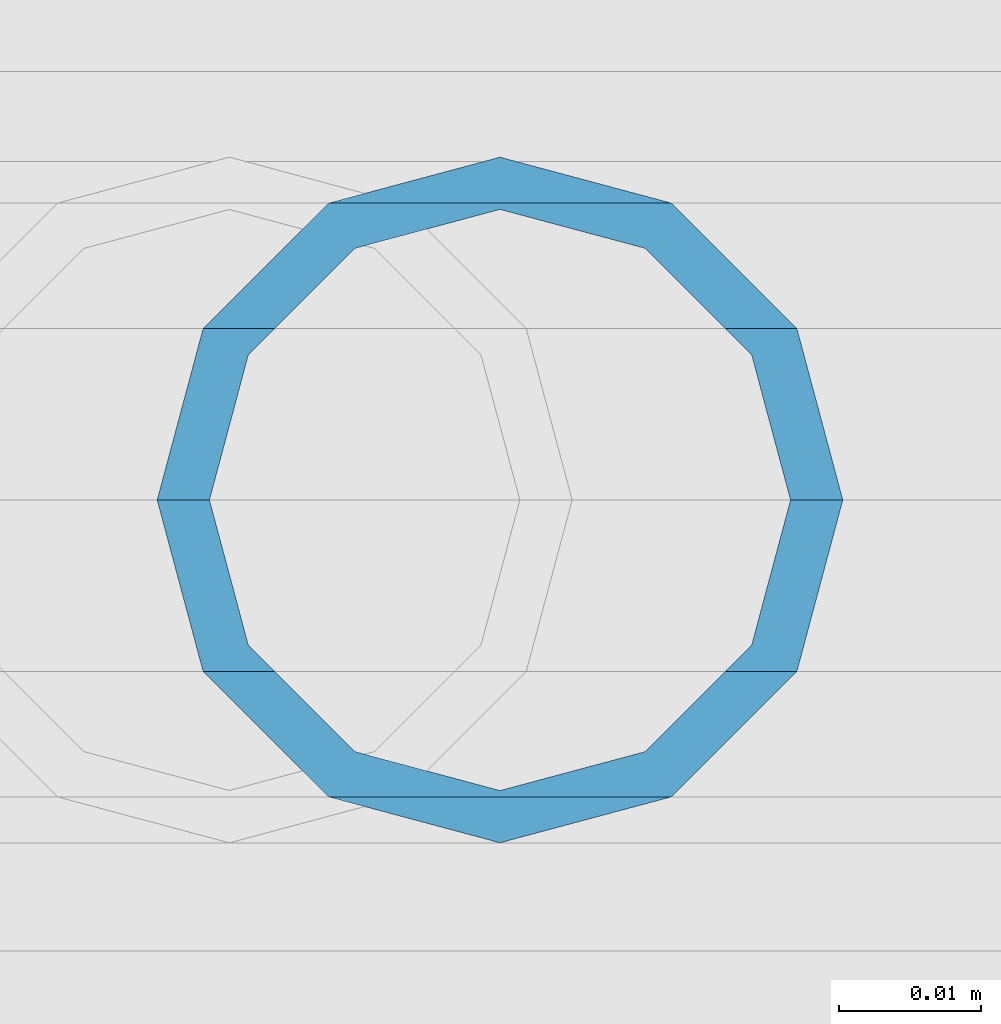
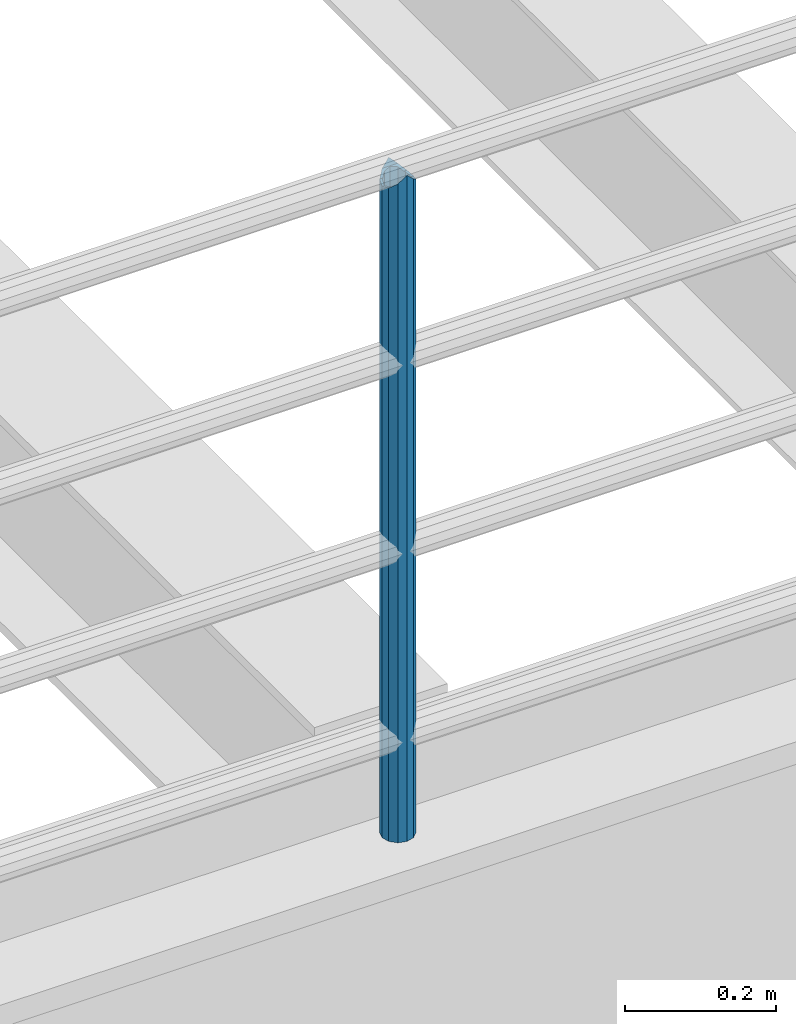
# One storey, part 636 of 1876: 1 column, 1 element without a shape of its own.
"""IFC2X3 building model written with IfcOpenShell, lengths in millimetres."""

from ifc_helpers import new_model, si_unit, frame, origin_with_axes, place, context, subcontext, project, spatial, faceted_brep, material, type_object, element, aggregate, save


model = new_model("IFC2X3")

# Units and contexts
model_context = context("Model", 3, precision=1e-05, world=origin_with_axes())
body_context = subcontext(model_context, "Body", "Model", "MODEL_VIEW")
ifc_project = project(units=[si_unit("LENGTHUNIT", "METRE", prefix="MILLI"), si_unit("AREAUNIT", "SQUARE_METRE"), si_unit("VOLUMEUNIT", "CUBIC_METRE"), si_unit("MASSUNIT", "GRAM", prefix="KILO"), si_unit("TIMEUNIT", "SECOND"), si_unit("PLANEANGLEUNIT", "RADIAN"), si_unit("SOLIDANGLEUNIT", "STERADIAN"), si_unit("THERMODYNAMICTEMPERATUREUNIT", "DEGREE_CELSIUS"), si_unit("LUMINOUSINTENSITYUNIT", "LUMEN")], contexts=[model_context])

# Site, building, storey
site_placement = place(None, origin_with_axes())
site = spatial("IfcSite", under=ifc_project, at=site_placement, CompositionType="ELEMENT")
building_placement = place(site_placement, origin_with_axes())
building = spatial("IfcBuilding", under=site, at=building_placement, Name="Undefined", CompositionType="ELEMENT")
storey_placement = place(building_placement, origin_with_axes())
storey = spatial("IfcBuildingStorey", under=building, at=storey_placement, Name="Undefined", CompositionType="ELEMENT", Elevation=0.0)

# Assembly, column
assembly_placement = place(storey_placement, origin_with_axes())
assembly = element("IfcElementAssembly", 1, at=assembly_placement, inside=storey, Name="RAIL", AssemblyPlace="NOTDEFINED", PredefinedType="RIGID_FRAME")
ifc_material = material()
column_type = type_object("IfcColumnType", Name="PIPE1-1/2SCH40", PredefinedType="NOTDEFINED")
column_placement = place(assembly_placement, frame((5067.30000007785, -4654.55000114554, 5130.8), z_axis=(1.0, 0.0, 0.0), x_axis=(0.0, 0.0, 1.0)))
column = element("IfcColumn", 2, at=column_placement, type_object=column_type, material=ifc_material, Name="POST", ObjectType="PIPE1-1/2SCH40", context=body_context, shape_type="Brep", body=[
    faceted_brep([(1055.42780700668, -12.0650000000001, 20.8971929933186), (1055.42780700668, -12.0650000000001, 15.8661214311805), (1054.93437856882, -10.2235000000001, 17.7076214311801), (1052.195, 0.0, 20.4470000000001), (1052.195, 0.0, 24.1300000000001), (1054.93437856882, 10.2235000000001, 17.7076214311801), (1055.42780700668, 12.0650000000001, 15.8661214311805), (1055.42780700668, 12.0650000000001, 20.8971929933186), (1076.325, 24.1300000000001, 0.0), (1064.26, 20.8971929933184, 12.0649999999996), (1064.25999999999, 20.8971929933186, -12.0649999999996), (1061.07042843786, 17.7076214311803, 10.2235000000001), (1063.80980700668, 20.4469999999999, 0.0), (1061.07042843786, 17.7076214311803, -10.2235000000001), (1055.42780700668, 12.0650000000001, -15.8661214311805), (1055.42780700667, 12.0649999999996, -20.8971929933186), (1054.93437856882, 10.2235000000001, -17.7076214311801), (1052.195, 0.0, -20.4470000000001), (1052.19499999999, 0.0, -24.1300000000001), (1055.42780700668, -12.0650000000001, -15.8661214311805), (1055.42780700667, -12.0649999999996, -20.8971929933186), (1054.93437856882, -10.2235000000001, -17.7076214311801), (1076.325, -24.1300000000001, 0.0), (1064.25999999999, -20.8971929933186, -12.0649999999996), (1064.26, -20.8971929933184, 12.0649999999996), (1061.07042843786, -17.7076214311803, -10.2235000000001), (1063.80980700668, -20.4469999999999, 0.0), (1061.07042843786, -17.7076214311803, 10.2235000000001), (0.0, -20.8971929933184, -12.0649999999996), (0.0, -12.0650000000001, -20.8971929933186), (-1.45519152283669e-11, 0.0, -24.130000000001), (0.0, 12.0650000000001, -20.8971929933186), (0.0, 20.8971929933184, -12.0649999999996), (0.0, 24.1299999999992, 0.0), (0.0, 20.8971929933184, 12.0649999999996), (0.0, 12.0650000000001, 20.8971929933186), (-1.45519152283669e-11, 0.0, 24.130000000001), (0.0, -12.0650000000001, 20.8971929933186), (0.0, -20.8971929933184, 12.0649999999996), (0.0, -24.1299999999992, 0.0), (0.0, -17.7076214311803, -10.2235000000001), (0.0, -10.2235000000001, -17.7076214311801), (-1.45519152283669e-11, 0.0, -20.4470000000001), (0.0, 10.2235000000001, -17.7076214311801), (0.0, 17.7076214311803, -10.2235000000001), (0.0, 20.4469999999999, 0.0), (0.0, 17.7076214311803, 10.2235000000001), (0.0, 10.2235000000001, 17.7076214311801), (-1.45519152283669e-11, 0.0, 20.4470000000001), (0.0, -10.2235000000001, 17.7076214311801), (0.0, -17.7076214311803, 10.2235000000001), (0.0, -20.4469999999999, 0.0)], [[[0, 1, 2, 3, 4]], [[4, 3, 5, 6, 7]], [[8, 9, 10]], [[7, 6, 11, 12, 13, 14, 15, 10, 9]], [[16, 17, 18, 15, 14]], [[19, 20, 18, 17, 21]], [[22, 23, 24]], [[24, 23, 20, 19, 25, 26, 27, 1, 0]], [[28, 29, 20, 23]], [[29, 30, 18, 20]], [[30, 31, 15, 18]], [[31, 32, 10, 15]], [[32, 33, 8, 10]], [[33, 34, 9, 8]], [[34, 35, 7, 9]], [[35, 36, 4, 7]], [[36, 37, 0, 4]], [[37, 38, 24, 0]], [[38, 39, 22, 24]], [[39, 28, 23, 22]], [[38, 37, 36, 35, 34, 33, 32, 31, 30, 29, 28, 39], [40, 41, 42, 43, 44, 45, 46, 47, 48, 49, 50, 51]], [[40, 51, 26, 25]], [[21, 41, 40, 25, 19]], [[42, 41, 21, 17]], [[43, 42, 17, 16]], [[44, 43, 16, 14, 13]], [[45, 44, 13, 12]], [[46, 45, 12, 11]], [[5, 47, 46, 11, 6]], [[48, 47, 5, 3]], [[49, 48, 3, 2]], [[50, 49, 2, 1, 27]], [[51, 50, 27, 26]]]),
])
aggregate(assembly, [column])

save(model, "model.ifc")
